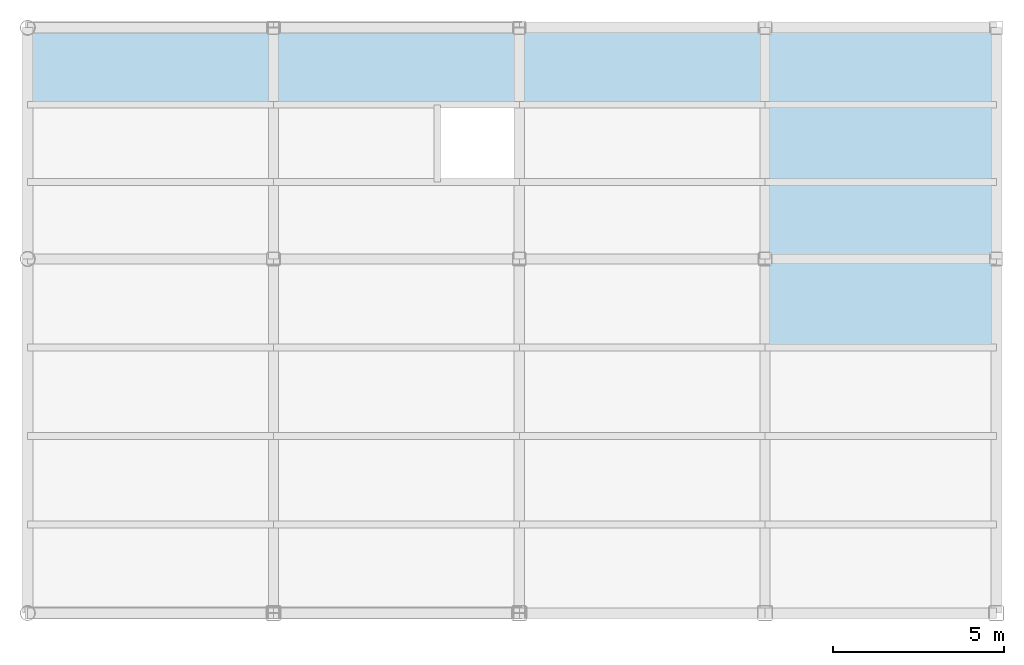
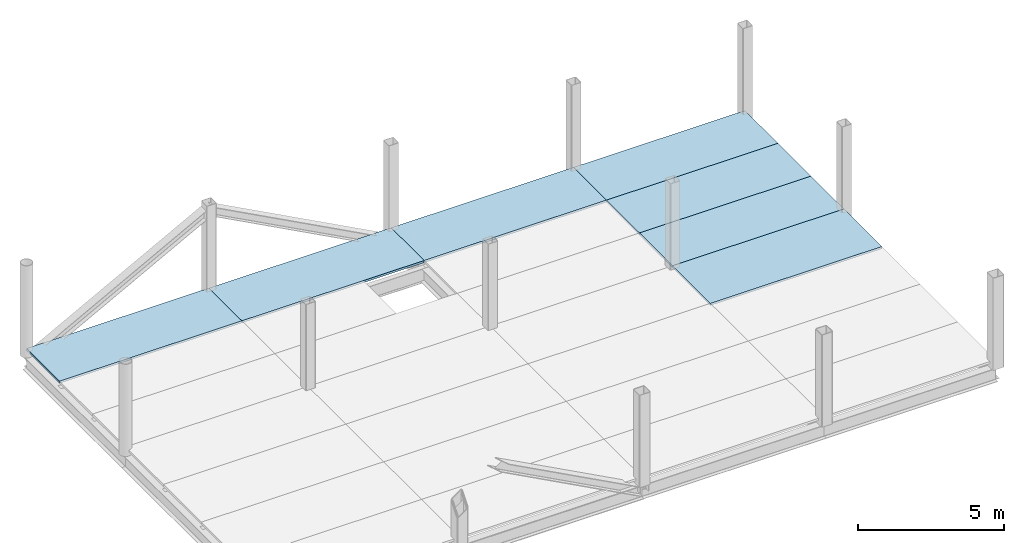
# One storey, part 2 of 2: 7 slabs.
"""IFC2X3 building model written with IfcOpenShell, lengths in millimetres."""

from ifc_helpers import new_model, si_unit, frame, origin_with_axes, place, context, subcontext, project, spatial, polyline, outline, extrude, material, layer, layer_set, layer_usage, type_object, element, save


model = new_model("IFC2X3")

# Units and contexts
model_context = context("Model", 3, precision=1e-05, world=origin_with_axes())
body_context = subcontext(model_context, "Body", "Model", "MODEL_VIEW")
ifc_project = project(units=[si_unit("LENGTHUNIT", "METRE", prefix="MILLI"), si_unit("AREAUNIT", "SQUARE_METRE"), si_unit("VOLUMEUNIT", "CUBIC_METRE"), si_unit("MASSUNIT", "GRAM", prefix="KILO"), si_unit("TIMEUNIT", "SECOND"), si_unit("PLANEANGLEUNIT", "RADIAN"), si_unit("SOLIDANGLEUNIT", "STERADIAN"), si_unit("THERMODYNAMICTEMPERATUREUNIT", "DEGREE_CELSIUS"), si_unit("LUMINOUSINTENSITYUNIT", "LUMEN")], contexts=[model_context])

# Site, building, storey
site_placement = place(None, origin_with_axes())
site = spatial("IfcSite", under=ifc_project, at=site_placement, CompositionType="ELEMENT")
building_placement = place(site_placement, origin_with_axes())
building = spatial("IfcBuilding", under=site, at=building_placement, Name="Undefined", CompositionType="ELEMENT")
storey_placement = place(building_placement, origin_with_axes())
storey = spatial("IfcBuildingStorey", under=building, at=storey_placement, Name="2", CompositionType="ELEMENT", Elevation=0.0)

# Slabs
ifc_material = material(Name="CONCRETE/FC24")
ifc_layer = layer(ifc_material, 90.0)
ifc_layer_set = layer_set([ifc_layer], Name="Floor: Insitu CONCRETE/FC24")
ifc_layer_usage_1 = layer_usage(ifc_layer_set, "AXIS3", "POSITIVE", -45.0)
slab_type_1 = type_object("IfcSlabType", PredefinedType="NOTDEFINED")
slab_1_placement = place(storey_placement, frame((21600.0, 14891.7, 4355.0), z_axis=(0.0, 0.0, 1.0), x_axis=(1.0, 0.0, 0.0)))
element("IfcSlab", 1, at=slab_1_placement, inside=storey, type_object=slab_type_1, material=ifc_layer_usage_1, Name="2SB4.3", PredefinedType="FLOOR", context=body_context, shape_type="SweptSolid", body=[
    extrude(outline(polyline([(0.0, 0.0), (7200.0, 0.0), (7200.0, 2258.30004882813), (0.0, 2258.30004882813), (0.0, 0.0)])), frame((0.0, 0.0, -45.0), z_axis=(0.0, 0.0, 1.0), x_axis=(1.0, 0.0, 0.0)), (0.0, 0.0, 1.0), 90.0),
])
ifc_layer_usage_2 = layer_usage(ifc_layer_set, "AXIS3", "POSITIVE", -45.0)
slab_2_placement = place(storey_placement, frame((36000.0, 14891.7, 4355.0), z_axis=(0.0, 0.0, 1.0), x_axis=(1.0, 0.0, 0.0)))
element("IfcSlab", 2, at=slab_2_placement, inside=storey, type_object=slab_type_1, material=ifc_layer_usage_2, Name="2SB6.3", PredefinedType="FLOOR", context=body_context, shape_type="SweptSolid", body=[
    extrude(outline(polyline([(0.0, 0.0), (6775.0, 0.0), (6775.0, 2258.30004882813), (0.0, 2258.30004882813), (0.0, 0.0)])), frame((0.0, 0.0, -45.0), z_axis=(0.0, 0.0, 1.0), x_axis=(1.0, 0.0, 0.0)), (0.0, 0.0, 1.0), 90.0),
])
ifc_layer_usage_3 = layer_usage(ifc_layer_set, "AXIS3", "POSITIVE", -45.0)
slab_3_placement = place(storey_placement, frame((36000.0, 12633.3, 4355.0), z_axis=(0.0, 0.0, 1.0), x_axis=(1.0, 0.0, 0.0)))
element("IfcSlab", 3, at=slab_3_placement, inside=storey, type_object=slab_type_1, material=ifc_layer_usage_3, Name="2SB6.2", PredefinedType="FLOOR", context=body_context, shape_type="SweptSolid", body=[
    extrude(outline(polyline([(0.0, 0.0), (6775.0, 0.0), (6775.0, 1341.69995117188), (6775.0, 2258.39990234375), (0.0, 2258.39990234375), (0.0, 1341.69995117188), (0.0, 0.0)])), frame((0.0, 0.0, -45.0), z_axis=(0.0, 0.0, 1.0), x_axis=(1.0, 0.0, 0.0)), (0.0, 0.0, 1.0), 90.0),
])
ifc_layer_usage_4 = layer_usage(ifc_layer_set, "AXIS3", "POSITIVE", -45.0)
slab_4_placement = place(storey_placement, frame((28800.0, 14891.7, 4355.0), z_axis=(0.0, 0.0, 1.0), x_axis=(1.0, 0.0, 0.0)))
element("IfcSlab", 4, at=slab_4_placement, inside=storey, type_object=slab_type_1, material=ifc_layer_usage_4, Name="2SB5.3", PredefinedType="FLOOR", context=body_context, shape_type="SweptSolid", body=[
    extrude(outline(polyline([(0.0, 0.0), (7200.0, 0.0), (7200.0, 2258.30004882813), (0.0, 2258.30004882813), (0.0, 0.0)])), frame((0.0, 0.0, -45.0), z_axis=(0.0, 0.0, 1.0), x_axis=(1.0, 0.0, 0.0)), (0.0, 0.0, 1.0), 90.0),
])
ifc_layer_usage_5 = layer_usage(ifc_layer_set, "AXIS3", "POSITIVE", -45.0)
slab_5_placement = place(storey_placement, frame((36000.0, 10375.0, 4355.0), z_axis=(0.0, 0.0, 1.0), x_axis=(1.0, 0.0, 0.0)))
element("IfcSlab", 5, at=slab_5_placement, inside=storey, type_object=slab_type_1, material=ifc_layer_usage_5, Name="2SB6.1", PredefinedType="FLOOR", context=body_context, shape_type="SweptSolid", body=[
    extrude(outline(polyline([(0.0, 0.0), (6775.0, 0.0), (6775.0, 2258.30004882813), (0.0, 2258.30004882813), (0.0, 0.0)])), frame((0.0, 0.0, -45.0), z_axis=(0.0, 0.0, 1.0), x_axis=(1.0, 0.0, 0.0)), (0.0, 0.0, 1.0), 90.0),
])
ifc_layer_usage_6 = layer_usage(ifc_layer_set, "AXIS3", "POSITIVE", -45.0)
slab_6_placement = place(storey_placement, frame((14400.0, 14891.7, 4355.0), z_axis=(0.0, 0.0, 1.0), x_axis=(1.0, 0.0, 0.0)))
element("IfcSlab", 6, at=slab_6_placement, inside=storey, type_object=slab_type_1, material=ifc_layer_usage_6, Name="2SB3.3", PredefinedType="FLOOR", context=body_context, shape_type="SweptSolid", body=[
    extrude(outline(polyline([(0.0, 0.0), (7200.0, 0.0), (7200.0, 2258.30004882813), (0.0, 2258.30004882813), (0.0, 0.0)])), frame((0.0, 0.0, -45.0), z_axis=(0.0, 0.0, 1.0), x_axis=(1.0, 0.0, 0.0)), (0.0, 0.0, 1.0), 90.0),
])
ifc_layer_usage_7 = layer_usage(ifc_layer_set, "AXIS3", "POSITIVE", -45.0)
slab_type_2 = type_object("IfcSlabType", PredefinedType="NOTDEFINED")
slab_7_placement = place(storey_placement, frame((36000.0, 7781.25, 4355.0), z_axis=(0.0, 0.0, 1.0), x_axis=(1.0, 0.0, 0.0)))
element("IfcSlab", 7, at=slab_7_placement, inside=storey, type_object=slab_type_2, material=ifc_layer_usage_7, Name="2SA6.4", PredefinedType="FLOOR", context=body_context, shape_type="SweptSolid", body=[
    extrude(outline(polyline([(0.0, 0.0), (6775.0, 0.0), (6775.0, 2593.75), (0.0, 2593.75), (0.0, 0.0)])), frame((0.0, 0.0, -45.0), z_axis=(0.0, 0.0, 1.0), x_axis=(1.0, 0.0, 0.0)), (0.0, 0.0, 1.0), 90.0),
])

save(model, "model.ifc")
